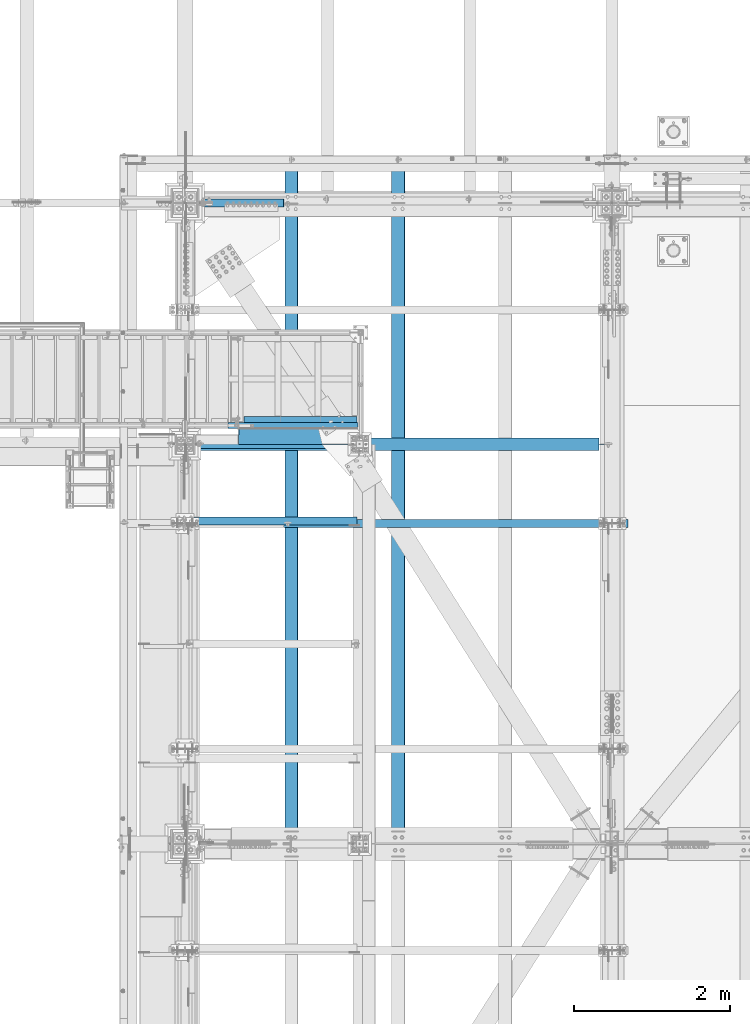
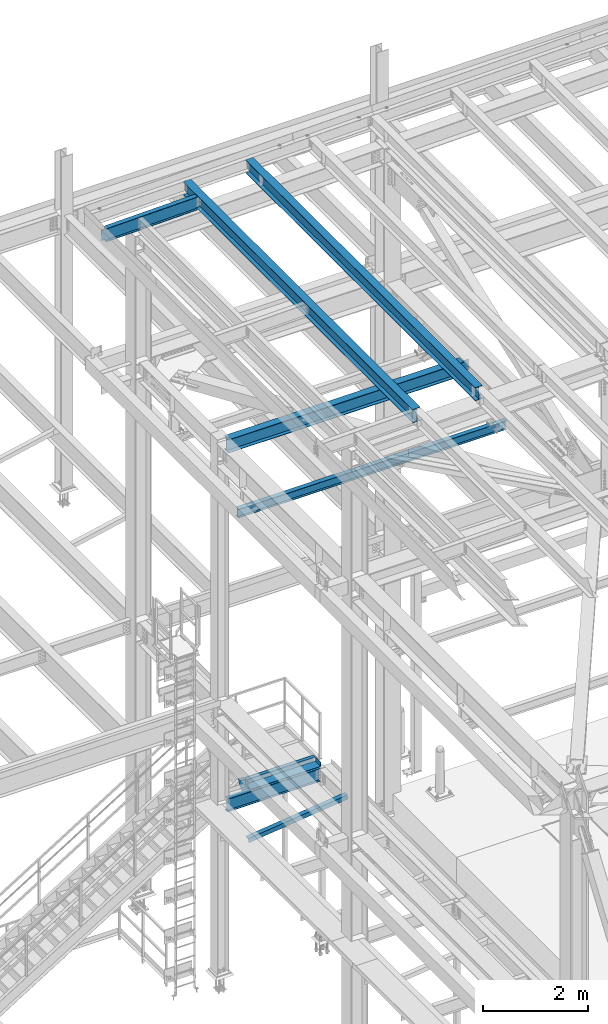
# One storey, part 1886 of 3843: 11 beams, 8 elements without a shape of their own.
"""IFC2X3 building model written with IfcOpenShell, lengths in millimetres."""

import ifcopenshell
import ifcopenshell.guid

model = None  # the IFC model being written
_history = None  # IfcOwnerHistory: only IFC2X3 demands one
_inside = {}  # id of a spatial element -> (the spatial element, [elements in it])
_under = {}  # id of a project, library or spatial element -> (it, [spatial elements below it])
_declared = {}  # id of a project -> (the project, [libraries it declares])
_typed = {}  # id of a type object -> (the type object, [elements of that type])
_made_of = {}  # id of a material, layer set ... -> (it, [elements and type objects made of it])


def new_model(schema):
    """Start an empty IFC model of exactly this schema.

    Asked for "IFC4X3", IfcOpenShell would pick the latest addendum, in which some entities
    have other attributes; the version numbers below select the first issue.
    IFC2X3 requires an IfcOwnerHistory on every rooted entity: one is made here for all.
    """
    global model, _history
    if schema == "IFC4X3":
        model = ifcopenshell.file(schema_version=(4, 3, 0, 0))
    else:
        model = ifcopenshell.file(schema=schema)
    _inside.clear()
    _under.clear()
    _declared.clear()
    _typed.clear()
    _made_of.clear()
    _history = None
    if model.schema == "IFC2X3":
        org = make("IfcOrganization", Name="unknown")
        user = make(
            "IfcPersonAndOrganization",
            ThePerson=make("IfcPerson", FamilyName="unknown"),
            TheOrganization=org,
        )
        app = make(
            "IfcApplication",
            ApplicationDeveloper=org,
            Version="unknown",
            ApplicationFullName="unknown",
            ApplicationIdentifier="unknown",
        )
        _history = make(
            "IfcOwnerHistory",
            OwningUser=user,
            OwningApplication=app,
            ChangeAction="ADDED",
            CreationDate=0,
        )
    return model


def make(cls, **values):
    """One entity of the class cls with the attributes given. An attribute that is None is left unset."""
    return model.create_entity(
        cls, **{name: value for name, value in values.items() if value is not None}
    )


def rooted(cls, **values):
    """An entity with a GlobalId (a new one), such as an element, a storey or a relation."""
    return make(cls, GlobalId=ifcopenshell.guid.new(), OwnerHistory=_history, **values)


def si_unit(unit_type, name, prefix=None):
    """IfcSIUnit, for example si_unit("LENGTHUNIT", "METRE", prefix="MILLI")."""
    return make("IfcSIUnit", UnitType=unit_type, Prefix=prefix, Name=name)


def assignment(units):
    """IfcUnitAssignment: the units of a project."""
    return None if units is None else make("IfcUnitAssignment", Units=units)


def point(xyz):
    """IfcCartesianPoint."""
    return None if xyz is None else make("IfcCartesianPoint", Coordinates=xyz)


def direction(xyz):
    """IfcDirection."""
    return None if xyz is None else make("IfcDirection", DirectionRatios=xyz)


def frame(location, z_axis=None, x_axis=None):
    """IfcAxis2Placement3D, a coordinate frame: its origin and axes. An axis left out is left unset."""
    return make(
        "IfcAxis2Placement3D",
        Location=point(location),
        Axis=direction(z_axis),
        RefDirection=direction(x_axis),
    )


def origin_with_axes():
    """The frame at (0, 0, 0) with the z axis (0, 0, 1) and the x axis (1, 0, 0) written out."""
    return frame((0.0, 0.0, 0.0), z_axis=(0.0, 0.0, 1.0), x_axis=(1.0, 0.0, 0.0))


def place(relative_to, where):
    """IfcLocalPlacement: puts the frame where relative to a parent placement (None: the world)."""
    return make(
        "IfcLocalPlacement", PlacementRelTo=relative_to, RelativePlacement=where
    )


def context(
    kind, dimensions, precision=None, world=None, true_north=None, identifier=None
):
    """IfcGeometricRepresentationContext, for example the 3D "Model" context."""
    return make(
        "IfcGeometricRepresentationContext",
        ContextIdentifier=identifier,
        ContextType=kind,
        CoordinateSpaceDimension=dimensions,
        Precision=precision,
        WorldCoordinateSystem=world,
        TrueNorth=true_north,
    )


def subcontext(parent, identifier, kind, view, scale=None):
    """IfcGeometricRepresentationSubContext, for example "Body" below "Model"."""
    return make(
        "IfcGeometricRepresentationSubContext",
        ContextIdentifier=identifier,
        ContextType=kind,
        ParentContext=parent,
        TargetScale=scale,
        TargetView=view,
    )


def project(units=None, contexts=None):
    """IfcProject with its units and contexts."""
    return rooted(
        "IfcProject",
        Name="project",
        RepresentationContexts=contexts,
        UnitsInContext=assignment(units),
    )


def spatial(cls, under=None, at=None, **own):
    """A site, building, storey or space (cls), placed at a placement, below another one or the project."""
    s = rooted(cls, ObjectPlacement=at, **own)
    if under is not None:
        _under.setdefault(under.id(), (under, []))[1].append(s)
    return s


def faces_of(points, faces, orient=None, outer=None):
    """IfcFace entities. A face is a list of loops; a loop is a list of indices into points, from 0.

    orient and outer hold one flag for each loop. By default every Orientation is true, the
    first loop of a face is its IfcFaceOuterBound and the others are IfcFaceBound.
    """
    made = []
    for i, loops in enumerate(faces):
        bounds = []
        for j, loop in enumerate(loops):
            is_outer = j == 0 if outer is None else outer[i][j]
            bounds.append(
                make(
                    "IfcFaceOuterBound" if is_outer else "IfcFaceBound",
                    Bound=make("IfcPolyLoop", Polygon=[points[k] for k in loop]),
                    Orientation=True if orient is None else orient[i][j],
                )
            )
        made.append(make("IfcFace", Bounds=bounds))
    return made


def faceted_brep(points, faces, orient=None, outer=None, voids=None):
    """IfcFacetedBrep: a solid bounded by flat faces; with voids (closed shells), ...WithVoids."""
    shared = [point(p) for p in points]
    hull = make("IfcClosedShell", CfsFaces=faces_of(shared, faces, orient, outer))
    if voids is None:
        return make("IfcFacetedBrep", Outer=hull)
    return make(
        "IfcFacetedBrepWithVoids",
        Outer=hull,
        Voids=[
            make(cls, CfsFaces=faces_of(shared, fs, o, b)) for cls, fs, o, b in voids
        ],
    )


def shape(context_of_items, identifier, shape_type, items):
    """IfcShapeRepresentation: the items that make up one representation, for example the "Body"."""
    return make(
        "IfcShapeRepresentation",
        ContextOfItems=context_of_items,
        RepresentationIdentifier=identifier,
        RepresentationType=shape_type,
        Items=items,
    )


def material(Name=None, Category=None):
    """IfcMaterial."""
    return make("IfcMaterial", Name=Name, Category=Category)


def made_of(thing, what):
    """Note that an element or type object is made of a material, layer set ...; save() writes the relation."""
    if what is not None:
        _made_of.setdefault(what.id(), (what, []))[1].append(thing)
    return thing


def type_object(cls, material=None, **own):
    """A type object (cls), such as IfcWallType, which elements share."""
    return made_of(rooted(cls, **own), material)


def element(
    cls,
    number,
    at=None,
    inside=None,
    cuts=None,
    type_object=None,
    material=None,
    context=None,
    identifier="Body",
    shape_type=None,
    held_by="IfcProductDefinitionShape",
    body=None,
    shapes=None,
    **own,
):
    """One element of the class cls, such as IfcWall. Its Tag is "e" and its number.

    at: its placement. inside: the storey or other place that contains it. cuts: it is an
    opening in that element (IfcRelVoidsElement). A single representation is given by context,
    identifier, shape_type and body (its items); several are given by shapes. held_by: the class
    of the entity that holds the representations. save() writes the other relations.
    """
    e = rooted(cls, Tag="e%d" % number, ObjectPlacement=at, **own)
    if body is not None:
        shapes = [shape(context, identifier, shape_type, body)]
    if shapes is not None:
        e.Representation = make(held_by, Representations=shapes)
    if inside is not None:
        _inside.setdefault(inside.id(), (inside, []))[1].append(e)
    if cuts is not None:
        rooted(
            "IfcRelVoidsElement", RelatingBuildingElement=cuts, RelatedOpeningElement=e
        )
    if type_object is not None:
        _typed.setdefault(type_object.id(), (type_object, []))[1].append(e)
    return made_of(e, material)


def aggregate(whole, parts):
    """IfcRelAggregates: a whole, such as a stair, and the parts it consists of."""
    return rooted("IfcRelAggregates", RelatingObject=whole, RelatedObjects=parts)


def save(model, path):
    """Write the relations noted so far, then the file.

    IfcRelAggregates (storeys below a building ...), IfcRelContainedInSpatialStructure (elements
    in a storey), IfcRelDefinesByType, IfcRelAssociatesMaterial and IfcRelDeclares: one each for
    every whole, place, type object, material and project.
    """
    for whole, parts in _under.values():
        aggregate(whole, parts)
    for where, things in _inside.values():
        rooted(
            "IfcRelContainedInSpatialStructure",
            RelatedElements=things,
            RelatingStructure=where,
        )
    for kind, things in _typed.values():
        rooted("IfcRelDefinesByType", RelatedObjects=things, RelatingType=kind)
    for what, things in _made_of.values():
        rooted("IfcRelAssociatesMaterial", RelatedObjects=things, RelatingMaterial=what)
    for by, libraries in _declared.values():
        rooted("IfcRelDeclares", RelatingContext=by, RelatedDefinitions=libraries)
    model.write(path)


model = new_model("IFC2X3")

# Units and contexts
model_context = context("Model", 3, precision=1e-05, world=origin_with_axes())
body_context = subcontext(model_context, "Body", "Model", "MODEL_VIEW")
ifc_project = project(units=[si_unit("LENGTHUNIT", "METRE", prefix="MILLI"), si_unit("AREAUNIT", "SQUARE_METRE"), si_unit("VOLUMEUNIT", "CUBIC_METRE"), si_unit("MASSUNIT", "GRAM", prefix="KILO"), si_unit("TIMEUNIT", "SECOND"), si_unit("PLANEANGLEUNIT", "RADIAN"), si_unit("SOLIDANGLEUNIT", "STERADIAN"), si_unit("THERMODYNAMICTEMPERATUREUNIT", "DEGREE_CELSIUS"), si_unit("LUMINOUSINTENSITYUNIT", "LUMEN")], contexts=[model_context])

# Site, building, storey
site_placement = place(None, origin_with_axes())
site = spatial("IfcSite", under=ifc_project, at=site_placement, CompositionType="ELEMENT")
building_placement = place(site_placement, origin_with_axes())
building = spatial("IfcBuilding", under=site, at=building_placement, Name="Undefined", CompositionType="ELEMENT")
storey_placement = place(building_placement, origin_with_axes())
storey = spatial("IfcBuildingStorey", under=building, at=storey_placement, Name="Undefined", CompositionType="ELEMENT", Elevation=0.0)

# Assembly, beams
assembly_1_placement = place(storey_placement, origin_with_axes())
assembly_1 = element("IfcElementAssembly", 1, at=assembly_1_placement, inside=storey, Name="STAIR", AssemblyPlace="NOTDEFINED", PredefinedType="RIGID_FRAME")
ifc_material_1 = material(Name="STEEL/A36")
beam_type_1 = type_object("IfcBeamType", PredefinedType="NOTDEFINED")
beam_1_placement = place(assembly_1_placement, frame((37261.7999999913, 89357.2000001144, 34134.425), z_axis=(0.0, 1.0, 0.0), x_axis=(1.0, 0.0, 0.0)))
beam_1 = element("IfcBeam", 2, at=beam_1_placement, type_object=beam_type_1, material=ifc_material_1, Name="PLATE", context=body_context, shape_type="Brep", body=[
    faceted_brep([(0.0, 3.17500000000291, -38.0999999999985), (0.0, 3.17500000000291, 38.0999999999985), (1533.52500000346, 3.17500000000291, 38.1000000000058), (1533.52500000346, 3.17500000000291, -38.1000000000058), (0.0, -3.17500000000291, 38.0999999999985), (1533.52500000346, -3.17500000000291, 38.1000000000058), (0.0, -3.17500000000291, -38.0999999999985), (1533.52500000346, -3.17500000000291, -38.1000000000058)], [[[0, 1, 2, 3]], [[1, 4, 5, 2]], [[4, 6, 7, 5]], [[6, 0, 3, 7]], [[5, 7, 3, 2]], [[6, 4, 1, 0]]]),
])
beam_type_2 = type_object("IfcBeamType", Name="C12X20.7", PredefinedType="NOTDEFINED")
beam_2_placement = place(assembly_1_placement, frame((37127.5314299188, 89357.2000000485, 34010.6000000117), z_axis=(0.0, 0.0, 1.0), x_axis=(1.0, 0.0, 0.0)))
beam_2 = element("IfcBeam", 3, at=beam_2_placement, type_object=beam_type_2, material=ifc_material_1, Name="STAIR", ObjectType="C12X20.7", context=body_context, shape_type="Brep", body=[
    faceted_brep([(134.268570070926, -38.1000000000058, 152.400000000001), (134.268570070926, -38.1000000000058, 146.047460000002), (134.268570070926, 30.1625000000058, 134.674927499997), (134.268570070926, 30.1625000000058, 120.650000074354), (134.268570070926, 38.1000000000058, 120.650000082271), (134.268570070926, 38.1000000000058, 152.400000000001), (1667.7935700748, 30.1625000000058, 120.650000074376), (1667.7935700725, 38.1000000000058, 120.650000082293), (87.2228414294514, -38.1000000000058, -152.400000000001), (85.4049720575931, -38.1000000000058, -146.047460000002), (82.1505606706269, 30.1625000000058, -134.674927499997), (5.07228147550632, 30.1625000000058, 134.674927499997), (1.8178700885328, -38.1000000000058, 146.047460000002), (0.0, -38.0999999999985, 152.400000000001), (0.0, 38.0999999999985, 152.400000000001), (87.2228414294514, 38.1000000000058, -152.400000000001), (1667.7935700725, 38.1000000000058, -152.400000000001), (1667.7935700725, -38.1000000000058, -152.400000000001), (1667.7935700725, -38.1000000000058, -146.047460000002), (1667.7935700725, 30.1625000000058, -134.674927499997)], [[[0, 1, 2, 3, 4, 5]], [[6, 7, 4, 3]], [[8, 9, 10, 11, 12, 13, 14, 15]], [[8, 15, 16, 17]], [[9, 8, 17, 18]], [[10, 9, 18, 19]], [[2, 11, 10, 19, 6, 3]], [[12, 11, 2, 1]], [[13, 12, 1, 0]], [[14, 13, 0, 5]], [[16, 15, 14, 5, 4, 7]], [[19, 18, 17, 16, 7, 6]]]),
])

# Assembly, beam
assembly_2_placement = place(storey_placement, origin_with_axes())
assembly_2 = element("IfcElementAssembly", 4, at=assembly_2_placement, inside=storey, Name="ANGLE", AssemblyPlace="NOTDEFINED", PredefinedType="RIGID_FRAME")
ifc_material_2 = material(Name="STEEL/A572-50")
beam_type_3 = type_object("IfcBeamType", Name="L4X4X3/8", PredefinedType="NOTDEFINED")
beam_3_placement = place(assembly_2_placement, frame((38788.5093206542, 88128.475, 33960.1419503901), z_axis=(0.0, 1.0, 0.0), x_axis=(-0.993268693078032, 0.0, -0.115833084009098)))
beam_3 = element("IfcBeam", 5, at=beam_3_placement, type_object=beam_type_3, material=ifc_material_2, Name="ANGLE", ObjectType="L4X4X3/8", context=body_context, shape_type="Brep", body=[
    faceted_brep([(0.0, 50.8000000000029, -50.8000000000029), (0.0, 50.8000000000029, 50.8000000000029), (2192.8104802954, 50.7999999940694, 50.8000000000029), (2192.8104802954, 50.7999999940694, -50.8000000000029), (0.0, 41.2750000000015, 50.8000000000029), (2192.81048029537, 41.2749999940788, 50.8000000000029), (0.0, 41.2749999999942, -41.2750000000015), (2192.81048029537, 41.2749999940788, -41.2750000000015), (0.0, -50.8000000000029, -41.2750000000015), (2192.81048029512, -50.8000000058528, -41.2750000000015), (0.0, -50.8000000000029, -50.8000000000029), (2192.81048029512, -50.8000000058528, -50.8000000000029)], [[[0, 1, 2, 3]], [[1, 4, 5, 2]], [[4, 6, 7, 5]], [[6, 8, 9, 7]], [[8, 10, 11, 9]], [[10, 0, 3, 11]], [[5, 7, 9, 11, 3, 2]], [[10, 8, 6, 4, 1, 0]]]),
])
aggregate(assembly_2, [beam_3])

assembly_3_placement = place(storey_placement, origin_with_axes())
assembly_3 = element("IfcElementAssembly", 6, at=assembly_3_placement, inside=storey, Name="BEAM", AssemblyPlace="NOTDEFINED", PredefinedType="RIGID_FRAME")
ifc_material_3 = material(Name="STEEL/A992")
beam_type_4 = type_object("IfcBeamType", Name="W12X26", PredefinedType="NOTDEFINED")
beam_4_placement = place(assembly_3_placement, frame((36576.0, 89115.9, 42246.55), z_axis=(0.0, 0.0, 1.0), x_axis=(1.0, 0.0, 0.0)))
beam_4 = element("IfcBeam", 7, at=beam_4_placement, type_object=beam_type_4, material=ifc_material_3, Name="BEAM", ObjectType="W12X26", context=body_context, shape_type="Brep", body=[
    faceted_brep([(5314.95, -3.17500000000291, -146.050000000003), (5314.95, -82.5500000000029, -146.050000000003), (5314.95, -82.5500000000029, -155.574999999997), (5314.95, 82.5500000000029, -155.574999999997), (5314.95, 82.5500000000029, -146.050000000003), (5314.95, 3.17500000000291, -146.050000000003), (5314.95, 3.17500000000291, -136.524999795321), (5314.95, -3.17500000000291, -136.524999795321), (5315.9167299226, 3.17500000000291, -131.664920277275), (5315.9167299226, -3.17500000000291, -131.664920277275), (5318.66974382307, 3.17500000000291, -127.544743809121), (5318.66974382307, -3.17500000000291, -127.544743809121), (5322.78992029122, 3.17500000000291, -124.791729908648), (5322.78992029122, -3.17500000000291, -124.791729908648), (5327.64999980927, 3.17500000000291, -123.824999986056), (5327.64999980927, -3.17500000000291, -123.824999986056), (5467.35000000001, -3.17500000000291, -123.824999986056), (5467.35000000001, 3.17500000000291, -123.824999986056), (142.875, 3.17500000000291, 146.050000000003), (142.875, 82.5500000000029, 146.050000000003), (5314.95, 82.5500000000029, 146.050000000003), (5314.95, 3.17500000000291, 146.050000000003), (142.875, -82.5500000000029, -155.574999999997), (142.875, -82.5500000000029, -146.050000000003), (142.875, -3.17500000000291, -146.050000000003), (142.875, -3.17500000000291, 146.050000000003), (142.875, -82.5500000000029, 146.050000000003), (142.875, -82.5500000000029, 155.574999999997), (142.875, 82.5500000000029, 155.574999999997), (142.875, 3.17500000000291, 117.474999999999), (142.875, 3.17500000000291, -113.125), (142.875, 3.17500000000291, -146.050000000003), (142.875, 82.5500000000029, -146.050000000003), (142.875, 82.5500000000029, -155.574999999997), (5314.95, -3.17500000000291, 146.050000000003), (5314.95, -82.5500000000029, 146.050000000003), (5314.95, -82.5500000000029, 155.574999999997), (5314.95, 82.5500000000029, 155.574999999997), (5314.95, -3.17500000000291, 136.52499982321), (5314.95, 3.17500000000291, 136.52499982321), (5315.9167299226, -3.17500000000291, 131.664920305164), (5315.9167299226, 3.17500000000291, 131.664920305164), (5318.66974382307, -3.17500000000291, 127.54474383701), (5318.66974382307, 3.17500000000291, 127.54474383701), (5322.78992029122, -3.17500000000291, 124.791729936536), (5322.78992029122, 3.17500000000291, 124.791729936536), (5327.64999980927, -3.17500000000291, 123.825000013945), (5327.64999980927, 3.17500000000291, 123.825000013945), (5467.35000000001, -3.17500000000291, 123.825000013945), (5467.35000000001, 3.17500000000291, 123.825000013945), (5467.35000000001, 3.17500000000291, -113.124999975276), (5467.35000000001, 3.17500000000291, 117.475000024722)], [[[0, 1, 2, 3, 4, 5, 6, 7]], [[7, 6, 8, 9]], [[9, 8, 10, 11]], [[11, 10, 12, 13]], [[13, 12, 14, 15]], [[16, 15, 14, 17]], [[18, 19, 20, 21]], [[22, 23, 24, 25, 26, 27, 28, 19, 18, 29, 30, 31, 32, 33]], [[26, 25, 34, 35]], [[27, 26, 35, 36]], [[28, 27, 36, 37]], [[19, 28, 37, 20]], [[36, 35, 34, 38, 39, 21, 20, 37]], [[40, 41, 39, 38]], [[42, 43, 41, 40]], [[44, 45, 43, 42]], [[46, 47, 45, 44]], [[48, 49, 47, 46]], [[50, 51, 49, 48, 16, 17]], [[12, 10, 8, 6, 5, 31, 30, 29, 18, 21, 39, 41, 43, 45, 47, 49, 51, 50, 17, 14]], [[32, 31, 5, 4]], [[33, 32, 4, 3]], [[22, 33, 3, 2]], [[23, 22, 2, 1]], [[24, 23, 1, 0]], [[48, 46, 44, 42, 40, 38, 34, 25, 24, 0, 7, 9, 11, 13, 15, 16]]]),
])
aggregate(assembly_3, [beam_4])

assembly_4_placement = place(storey_placement, origin_with_axes())
assembly_4 = element("IfcElementAssembly", 8, at=assembly_4_placement, inside=storey, Name="BEAM", AssemblyPlace="NOTDEFINED", PredefinedType="RIGID_FRAME")
beam_5_placement = place(assembly_4_placement, frame((39315.9092623549, 83985.1232899491, 45633.2761568835), z_axis=(-0.0211520982443035, 0.000149702000009711, 0.999776258134376), x_axis=(0.0, 0.999999988789565, -0.000149735999968411)))
beam_5 = element("IfcBeam", 9, at=beam_5_placement, type_object=beam_type_4, material=ifc_material_3, Name="BEAM", ObjectType="W12X26", context=body_context, shape_type="Brep", body=[
    faceted_brep([(8748.71286122, -3.17499999989377, -146.049999991708), (8748.71286122002, -82.5499999997555, -146.049999991512), (8748.71286122, -82.5499999997337, -155.574999991521), (8748.71286122, 82.5499999999884, -155.574999991921), (8748.71286122002, 82.5499999999738, -146.049999991912), (8748.71286122, 3.17500000010477, -146.049999991723), (8748.7128612212, 3.1750000000975, -142.874999700573), (8748.71286122112, -3.17499999989377, -142.874999700529), (8749.67959114375, 3.17500000009022, -138.014920182519), (8749.67959114365, -3.17499999990105, -138.014920182482), (8752.4326050442, 3.17500000008295, -133.89474371438), (8752.43260504413, -3.17499999990832, -133.894743714329), (8756.55278151239, 3.17500000007567, -131.141729813913), (8756.55278151232, -3.1749999999156, -131.141729813869), (8761.41286103048, 3.17500000007567, -130.174999891344), (8761.4128610304, -3.1749999999156, -130.174999891293), (8818.5587864485, -3.1749999999156, -130.174999891518), (8818.55880656045, 3.17500000007567, -130.174999891511), (12.6548561980599, 3.17499999971915, 146.050000000178), (12.6551075974858, 82.5499999995809, 146.049999999988), (8748.71286121653, 82.549999999399, 146.050000008428), (8748.71286121651, 3.17499999954453, 146.050000008618), (12.6997740084771, -82.5500000001266, -155.575000000601), (12.6983127888088, -82.5499999995736, -146.049999999959), (12.6985153056303, -3.1750000001266, -146.049999999974), (12.6548360861052, -3.17500000027212, 146.050000000192), (12.6545846867084, -82.5500000001339, 146.050000000389), (12.6531587703212, -82.5500000001557, 155.575000000397), (12.6536816811131, 82.5499999995664, 155.57499999999), (12.6985359631362, 3.17499999986467, -146.049999999996), (12.6987941820043, 82.549999999741, -146.050000000265), (12.7002263236427, 82.5499999995591, -155.575000000172), (8748.71286121651, -3.17500000044674, 146.050000008632), (8748.71286121651, -82.5500000003158, 146.050000008829), (8748.71286121653, -82.5500000003376, 155.575000008837), (8748.71286121653, 82.5499999993917, 155.575000008437), (8748.71286121788, -3.17500000044674, 142.874999919026), (8748.71286121797, 3.17499999954453, 142.874999918989), (8749.67959114054, -3.17500000043947, 138.01492040095), (8749.67959114061, 3.1749999995518, 138.014920400907), (8752.4326050411, -3.17500000041764, 133.894743932753), (8752.43260504119, 3.17499999956635, 133.894743932709), (8756.55278150937, -3.17500000041764, 131.141730032243), (8756.55278150944, 3.17499999956635, 131.141730032199), (8761.41286102751, -3.17500000041764, 130.175000109637), (8761.41286102759, 3.17499999957363, 130.175000109593), (8818.51981140097, -3.17500000041764, 130.175000110881), (8818.51983151292, 3.17499999956635, 130.175000110889), (8818.55625342086, 3.17500000003929, -113.120244814017), (8818.52173202329, 3.17499999958818, 117.479752603125)], [[[0, 1, 2, 3, 4, 5, 6, 7]], [[7, 6, 8, 9]], [[9, 8, 10, 11]], [[11, 10, 12, 13]], [[13, 12, 14, 15]], [[16, 15, 14, 17]], [[18, 19, 20, 21]], [[22, 23, 24, 25, 26, 27, 28, 19, 18, 29, 30, 31]], [[26, 25, 32, 33]], [[27, 26, 33, 34]], [[28, 27, 34, 35]], [[19, 28, 35, 20]], [[34, 33, 32, 36, 37, 21, 20, 35]], [[38, 39, 37, 36]], [[40, 41, 39, 38]], [[42, 43, 41, 40]], [[44, 45, 43, 42]], [[46, 47, 45, 44]], [[48, 49, 47, 46, 16, 17]], [[12, 10, 8, 6, 5, 29, 18, 21, 37, 39, 41, 43, 45, 47, 49, 48, 17, 14]], [[30, 29, 5, 4]], [[31, 30, 4, 3]], [[22, 31, 3, 2]], [[23, 22, 2, 1]], [[24, 23, 1, 0]], [[46, 44, 42, 40, 38, 36, 32, 25, 24, 0, 7, 9, 11, 13, 15, 16]]]),
])
aggregate(assembly_4, [beam_5])

assembly_5_placement = place(storey_placement, origin_with_axes())
assembly_5 = element("IfcElementAssembly", 10, at=assembly_5_placement, inside=storey, Name="BEAM", AssemblyPlace="NOTDEFINED", PredefinedType="RIGID_FRAME")
beam_6_placement = place(assembly_5_placement, frame((37944.3092623846, 83985.1116450134, 45603.5956776366), z_axis=(-0.0211520980636923, 7.39979999707428e-05, 0.999776266607585), x_axis=(2.20000000365173e-08, 0.99999999726089, -7.40150000196403e-05)))
beam_6 = element("IfcBeam", 11, at=beam_6_placement, type_object=beam_type_4, material=ifc_material_3, Name="BEAM", ObjectType="W12X26", context=body_context, shape_type="Brep", body=[
    faceted_brep([(8748.712654394, -3.17499999990105, -146.050000027157), (8748.712654394, -82.549999999741, -146.050000027375), (8748.71265439395, -82.5499999997846, -155.575000027362), (8748.71265439395, 82.5499999998865, -155.575000026911), (8748.71265439398, 82.5499999999156, -146.050000026917), (8748.71265439398, 3.17500000007567, -146.050000027135), (8748.71265439461, 3.17500000008295, -142.875000296546), (8748.71265439456, -3.17499999990105, -142.875000296604), (8749.67938431721, 3.1750000000975, -138.014920778529), (8749.67938431716, -3.17499999987922, -138.01492077858), (8752.43239821767, 3.17500000011933, -133.894744310397), (8752.43239821763, -3.17499999987194, -133.894744310455), (8756.55257468575, 3.17500000013388, -131.141730409945), (8756.5525746857, -3.17499999985739, -131.141730410003), (8761.4126542037, 3.17500000013388, -130.175000487376), (8761.41265420365, -3.17499999985739, -130.175000487427), (8818.56061830452, -3.17499999985012, -130.175000488431), (8818.56062836049, 3.17500000013388, -130.175000488445), (12.6774280250684, 3.1750000004904, 146.049999999806), (12.677553724774, 82.5500000003303, 146.050000000032), (8748.71265439989, 82.5500000009051, 146.049999972733), (8748.71265439989, 3.1750000010652, 146.049999972514), (12.6998726767124, -82.5500000001921, -155.575000000106), (12.6991678371196, -82.5500000001703, -146.050000000097), (12.6992903581922, -3.17500000032305, -146.050000000112), (12.6774179690838, -3.17499999948632, 146.049999999792), (12.6772922693635, -82.5499999993262, 146.049999999574), (12.6765793112281, -82.5499999992971, 155.574999999561), (12.6768407666386, 82.5500000003667, 155.575000000019), (12.6993001598748, 3.17499999966822, -146.050000000112), (12.6994226809475, 82.5499999995009, -146.050000000127), (12.700127520533, 82.5499999994863, -155.575000000135), (8748.71265439989, -3.17499999891152, 146.049999972493), (8748.7126543999, -82.5499999987442, 146.049999972274), (8748.71265439993, -82.5499999987151, 155.574999972268), (8748.71265439993, 82.5500000009415, 155.57499997272), (8748.7126544004, -3.17499999892607, 142.874999320913), (8748.71265440043, 3.17500000105792, 142.874999320964), (8749.67938432295, -3.1749999989479, 138.014919802874), (8749.67938432298, 3.1750000010361, 138.014919802932), (8752.43239822335, -3.17499999896245, 133.894743334728), (8752.43239822339, 3.17500000102882, 133.894743334778), (8756.55257469141, -3.17499999896972, 131.141729434246), (8756.55257469145, 3.17500000101427, 131.141729434305), (8761.41265420937, -3.17499999896245, 130.174999511655), (8761.41265420943, 3.17500000101427, 130.174999511706), (8818.54113078186, -3.17499999896972, 130.174999510367), (8818.54114083783, 3.17500000101427, 130.174999510346), (8818.55935196872, 3.17500000019936, -113.122622912517), (8818.54209127078, 3.17500000097789, 117.477376435221)], [[[0, 1, 2, 3, 4, 5, 6, 7]], [[7, 6, 8, 9]], [[9, 8, 10, 11]], [[11, 10, 12, 13]], [[13, 12, 14, 15]], [[16, 15, 14, 17]], [[18, 19, 20, 21]], [[22, 23, 24, 25, 26, 27, 28, 19, 18, 29, 30, 31]], [[26, 25, 32, 33]], [[27, 26, 33, 34]], [[28, 27, 34, 35]], [[19, 28, 35, 20]], [[34, 33, 32, 36, 37, 21, 20, 35]], [[38, 39, 37, 36]], [[40, 41, 39, 38]], [[42, 43, 41, 40]], [[44, 45, 43, 42]], [[46, 47, 45, 44]], [[48, 49, 47, 46, 16, 17]], [[12, 10, 8, 6, 5, 29, 18, 21, 37, 39, 41, 43, 45, 47, 49, 48, 17, 14]], [[30, 29, 5, 4]], [[31, 30, 4, 3]], [[22, 31, 3, 2]], [[23, 22, 2, 1]], [[24, 23, 1, 0]], [[46, 44, 42, 40, 38, 36, 32, 25, 24, 0, 7, 9, 11, 13, 15, 16]]]),
])
aggregate(assembly_5, [beam_6])

# Beam
beam_type_5 = type_object("IfcBeamType", Name="L3X3X1/4", PredefinedType="NOTDEFINED")
beam_7_placement = place(assembly_1_placement, frame((38782.6249999936, 89433.4000000849, 34048.7000000118), z_axis=(0.0, 1.0, 0.0), x_axis=(-1.0, 0.0, 0.0)))
beam_7 = element("IfcBeam", 12, at=beam_7_placement, type_object=beam_type_5, material=ifc_material_1, Name="ANGLE", ObjectType="L3X3X1/4", context=body_context, shape_type="Brep", body=[
    faceted_brep([(0.0, 38.0999999999985, -38.0999999999985), (0.0, 38.0999999999985, 38.0999999999985), (1450.97500000388, 38.0999999999985, 38.1000000000058), (1450.97500000388, 38.0999999999985, -38.1000000000058), (0.0, 31.75, 38.0999999999985), (1450.97500000388, 31.75, 38.1000000000058), (0.0, 31.75, -31.75), (1450.97500000388, 31.75, -31.75), (0.0, -38.0999999999985, -31.75), (1450.97500000388, -38.0999999999985, -31.75), (0.0, -38.0999999999985, -38.0999999999985), (1450.97500000388, -38.0999999999985, -38.1000000000058)], [[[0, 1, 2, 3]], [[1, 4, 5, 2]], [[4, 6, 7, 5]], [[6, 8, 9, 7]], [[8, 10, 11, 9]], [[10, 0, 3, 11]], [[5, 7, 9, 11, 3, 2]], [[10, 8, 6, 4, 1, 0]]]),
])

aggregate(assembly_1, [beam_1, beam_7, beam_2])

# Assembly, beam
assembly_6_placement = place(storey_placement, origin_with_axes())
assembly_6 = element("IfcElementAssembly", 13, at=assembly_6_placement, inside=storey, Name="BEAM", AssemblyPlace="NOTDEFINED", PredefinedType="RIGID_FRAME")
beam_type_6 = type_object("IfcBeamType", PredefinedType="NOTDEFINED")
beam_8_placement = place(assembly_6_placement, frame((37264.9886704879, 89217.4999995969, 34137.5995719223), z_axis=(0.0, 1.0, 0.0), x_axis=(-0.000134551999977022, 4.9999291933285e-09, -0.99999999094788)))
beam_8 = element("IfcBeam", 14, at=beam_8_placement, type_object=beam_type_6, material=ifc_material_1, Name="BENT_PLATE", context=body_context, shape_type="Brep", body=[
    faceted_brep([(95.0515630808804, 3.17500003185705, 19.0499999285676), (95.050708675677, -3.17499996814149, 19.049999928553), (7.34544300939888e-06, -3.17500000000291, 19.0499452738004), (7.34331842977554e-06, 3.17500000000291, 19.0499452733056), (95.0515624425461, 3.17500003184978, -101.600036644872), (95.0507080373427, -3.17499996814877, -101.600036644551), (95.2516169301671, -3.17499996808328, 101.599963278015), (95.2466752458422, -3.17499996809056, -101.60003672009), (95.24911732693, -3.67986297828611, 101.599875236672), (95.2490396408248, -3.67500028877839, -101.600124705132), (94.5443994635061, -1524.00149578538, 101.563490545901), (95.0445549942015, -1524.00164085521, 101.563493164445), (95.0444773290219, -1523.99662262001, -101.636506773633), (94.5444773230847, -1523.99663311679, -101.636509395903), (-0.205444538813026, -1523.98388432452, -101.636545396585), (-0.205522398384346, -1523.98874699311, 101.563454545219), (101.59752970664, 3.17500003405439, -101.600039168508), (101.599039583351, -3.67585469389451, -101.60012715323), (101.393622866373, -1530.34747696584, -101.636661180455), (94.5436229178958, -1530.3466330575, -101.636661354627), (-0.206298944001901, -1530.33388426522, -101.636697355309), (101.602471390957, 3.17500003405439, 101.599960829597), (101.599117269448, -3.68071738340223, 101.599872788574), (101.393700531538, -1530.35249520104, 101.563338757624), (94.5435450583172, -1530.35149572608, 101.563338587177), (-0.206376803573221, -1530.33874693382, 101.563302586495), (0.0, 3.17499999999927, 101.600000000006), (0.0, -3.17499999999927, 101.600000000006)], [[[0, 1, 2, 3]], [[4, 5, 1, 0]], [[6, 7, 8]], [[9, 8, 7]], [[10, 11, 12, 13, 14, 15]], [[8, 9, 12, 11]], [[13, 12, 9, 7, 5, 4, 16, 17, 18, 19, 20, 14]], [[16, 21, 17]], [[22, 17, 21]], [[17, 22, 23, 18]], [[19, 18, 23, 24, 25, 20]], [[15, 14, 20, 25]], [[24, 23, 22, 8, 11, 10, 15, 25]], [[21, 26, 27, 6, 8, 22]], [[27, 26, 3, 2]], [[7, 6, 27, 2, 1, 5]], [[26, 21, 16, 4, 0, 3]]]),
])

assembly_7_placement = place(storey_placement, origin_with_axes())
assembly_7 = element("IfcElementAssembly", 15, at=assembly_7_placement, inside=storey, Name="BEAM", AssemblyPlace="NOTDEFINED", PredefinedType="RIGID_FRAME")
beam_type_7 = type_object("IfcBeamType", Name="W12X19", PredefinedType="NOTDEFINED")
beam_9_placement = place(assembly_7_placement, frame((35741.0571586918, 92214.7, 45557.9079249894), z_axis=(-0.0211520980073474, 0.0, 0.999776269347241), x_axis=(0.999776270257024, 0.0, 0.0211520550054619)))
beam_9 = element("IfcBeam", 16, at=beam_9_placement, type_object=beam_type_7, material=ifc_material_3, Name="BEAM", ObjectType="W12X19", context=body_context, shape_type="Brep", body=[
    faceted_brep([(2105.28760845413, -3.17500000000291, -144.462499997644), (2105.28760845413, -50.8000000000029, -144.462499997644), (2105.28760845414, -50.8000000000029, -153.987499997631), (2105.28760845414, 50.8000000000029, -153.987499997631), (2105.28760845413, 50.8000000000029, -144.462499997644), (2105.28760845413, 3.17500000000291, -144.462499997644), (2105.28760845413, 3.17500000000291, -141.28749993231), (2105.28760845413, -3.17500000000291, -141.28749993231), (2106.2543383767, 3.17500000000291, -136.427420414293), (2106.2543383767, -3.17500000000291, -136.427420414293), (2109.00735227716, 3.17500000000291, -132.307243946154), (2109.00735227716, -3.17500000000291, -132.307243946154), (2113.1275287453, 3.17500000000291, -129.55423004568), (2113.1275287453, -3.17500000000291, -129.55423004568), (2117.98760826332, 3.17500000000291, -128.587500123096), (2117.98760826332, -3.17500000000291, -128.587500123096), (2187.83753302703, -3.17500000000291, -128.587500123031), (2187.8375229728, 3.17500000000291, -128.587500123023), (96.8374980314547, 3.17500000000291, 144.462500000489), (96.8374980314547, 50.8000000000029, 144.462500000489), (2105.28760845168, 50.8000000000029, 144.462500001886), (2105.28760845168, 3.17500000000291, 144.462500001886), (96.8374977455387, -3.17500000000291, -141.287499907492), (96.8374977455387, 3.17500000000291, -141.287499907492), (96.8374977423518, 3.17500000000291, -144.462499999776), (96.8374977423518, 50.8000000000029, -144.462499999776), (96.8374977328203, 50.8000000000029, -153.987499999792), (96.8374977328203, -50.8000000000029, -153.987499999792), (96.8374977423518, -50.8000000000029, -144.462499999776), (96.8374977423518, -3.17500000000291, -144.462499999776), (95.8707678278151, -3.17500000000291, -136.427420388471), (95.8707678278151, 3.17500000000291, -136.427420388471), (93.1177539315104, -3.17500000000291, -132.307243917545), (93.1177539315104, 3.17500000000291, -132.307243917545), (88.9975774661289, -3.17500000000291, -129.554230012938), (88.9975774661289, 3.17500000000291, -129.554230012938), (84.1374979491229, -3.17500000000291, -128.587500085479), (84.1374979491229, 3.17500000000291, -128.587500085479), (20.6374979119428, -3.17500000000291, -128.587500021946), (20.6374979119428, 3.17500000000291, -128.587500021946), (20.637498196942, -3.17499999998836, -114.712499731744), (20.637499580218, -3.17499999998836, 115.887500264478), (20.637499711811, -3.17500000000291, 128.587499979069), (20.637499711811, 3.17500000000291, 128.587499979069), (84.1374982064444, -3.17500000000291, 128.587499915513), (84.1374982064444, 3.17500000000291, 128.587499915513), (88.9975777254003, -3.17500000000291, 129.554229833244), (88.9975777254003, 3.17500000000291, 129.554229833244), (93.1177541962679, -3.17500000000291, 132.307243729607), (93.1177541962679, 3.17500000000291, 132.307243729607), (95.8707681008382, -3.17500000000291, 136.427420195025), (95.8707681008382, 3.17500000000291, 136.427420195025), (96.8374980282824, -3.17500000000291, 141.287499712118), (96.8374980282824, 3.17500000000291, 141.287499712118), (96.8374980410154, -50.8000000000029, 153.987499285155), (96.8374980410008, 50.8000000000029, 153.987500000498), (96.8374980314547, -3.17500000000291, 144.462500000489), (96.8374980314547, -50.8000000000029, 144.462500000489), (2105.28760845168, -3.17500000000291, 144.462500001886), (2105.28760845168, -50.8000000000029, 144.462500001886), (2105.28760845168, -50.8000000000029, 153.987499994), (2105.28760845168, 50.8000000000029, 153.987500001873), (2105.28760845169, -3.17500000000291, 141.287499684891), (2105.28760845169, 3.17500000000291, 141.287499684891), (2106.25433837427, -3.17500000000291, 136.42742016686), (2106.25433837427, 3.17500000000291, 136.42742016686), (2109.00735227474, -3.17500000000291, 132.307243698728), (2109.00735227474, 3.17500000000291, 132.307243698728), (2113.12752874288, -3.17500000000291, 129.554229798276), (2113.12752874288, 3.17500000000291, 129.554229798276), (2117.98760826091, -3.17500000000291, 128.587499875692), (2117.98760826091, 3.17500000000291, 128.587499875692), (2187.83753302702, -3.17500000000291, 128.587499875764), (2187.83752297279, 3.17500000000291, 128.587499875764), (2187.83753302703, -3.17500000000291, 115.88749997336), (2187.83753302703, -3.17500000000291, -114.712500017522)], [[[0, 1, 2, 3, 4, 5, 6, 7]], [[7, 6, 8, 9]], [[9, 8, 10, 11]], [[11, 10, 12, 13]], [[13, 12, 14, 15]], [[16, 15, 14, 17]], [[18, 19, 20, 21]], [[22, 23, 24, 25, 26, 27, 28, 29]], [[30, 31, 23, 22]], [[32, 33, 31, 30]], [[34, 35, 33, 32]], [[36, 37, 35, 34]], [[38, 39, 37, 36]], [[40, 41, 42, 43, 39, 38]], [[44, 45, 43, 42]], [[46, 47, 45, 44]], [[48, 49, 47, 46]], [[50, 51, 49, 48]], [[52, 53, 51, 50]], [[54, 55, 19, 18, 53, 52, 56, 57]], [[57, 56, 58, 59]], [[54, 57, 59, 60]], [[55, 54, 60, 61]], [[19, 55, 61, 20]], [[60, 59, 58, 62, 63, 21, 20, 61]], [[64, 65, 63, 62]], [[66, 67, 65, 64]], [[68, 69, 67, 66]], [[70, 71, 69, 68]], [[72, 73, 71, 70]], [[73, 72, 74, 75, 16, 17]], [[12, 10, 8, 6, 5, 24, 23, 31, 33, 35, 37, 39, 43, 45, 47, 49, 51, 53, 18, 21, 63, 65, 67, 69, 71, 73, 17, 14]], [[25, 24, 5, 4]], [[26, 25, 4, 3]], [[27, 26, 3, 2]], [[28, 27, 2, 1]], [[29, 28, 1, 0]], [[75, 74, 72, 70, 68, 66, 64, 62, 58, 56, 52, 50, 48, 46, 44, 42, 41, 40, 38, 36, 34, 32, 30, 22, 29, 0, 7, 9, 11, 13, 15, 16]]]),
])
aggregate(assembly_7, [beam_9])

assembly_8_placement = place(storey_placement, origin_with_axes())
assembly_8 = element("IfcElementAssembly", 17, at=assembly_8_placement, inside=storey, Name="BEAM", AssemblyPlace="NOTDEFINED", PredefinedType="RIGID_FRAME")
beam_type_8 = type_object("IfcBeamType", Name="W8X13", PredefinedType="NOTDEFINED")
beam_10_placement = place(assembly_8_placement, frame((36372.8, 88099.9, 41402.0), z_axis=(0.0, 0.0, 1.0), x_axis=(1.0, 0.0, 0.0)))
beam_10 = element("IfcBeam", 18, at=beam_10_placement, type_object=beam_type_8, material=ifc_material_3, Name="BEAM", ObjectType="W8X13", context=body_context, shape_type="Brep", body=[
    faceted_brep([(0.0, 50.7999999999993, -101.599999999999), (0.0, 50.7999999999993, -95.25), (5892.8, 50.7999999999993, -95.25), (5892.8, 50.7999999999993, -101.599999999999), (0.0, 3.17499999999927, -95.25), (5892.8, 3.17499999999927, -95.25), (-2.44140610448085e-05, 3.17500000000291, 95.2499999999927), (5892.8, 3.17499999999927, 95.25), (0.0, 50.7999999999993, 95.25), (5892.8, 50.7999999999993, 95.25), (0.0, 50.7999999999993, 101.599999999999), (5892.8, 50.7999999999993, 101.599999999999), (0.0, -50.7999999999993, 101.599999999999), (5892.8, -50.7999999999993, 101.599999999999), (0.0, -50.7999999999993, 95.25), (5892.8, -50.7999999999993, 95.25), (0.0, -3.17499999999927, 95.25), (5892.8, -3.17499999999927, 95.25), (0.0, -3.17499999999927, -95.25), (5892.8, -3.17499999999927, -95.25), (0.0, -50.7999999999993, -95.25), (5892.8, -50.7999999999993, -95.25), (0.0, -50.7999999999993, -101.599999999999), (5892.8, -50.7999999999993, -101.599999999999)], [[[0, 1, 2, 3]], [[1, 4, 5, 2]], [[4, 6, 7, 5]], [[6, 8, 9, 7]], [[8, 10, 11, 9]], [[10, 12, 13, 11]], [[12, 14, 15, 13]], [[14, 16, 17, 15]], [[16, 18, 19, 17]], [[18, 20, 21, 19]], [[20, 22, 23, 21]], [[22, 0, 3, 23]], [[5, 7, 9, 11, 13, 15, 17, 19, 21, 23, 3, 2]], [[22, 20, 18, 16, 14, 12, 10, 8, 6, 4, 1, 0]]]),
])
aggregate(assembly_8, [beam_10])

# Beam
beam_type_9 = type_object("IfcBeamType", Name="W12X14", PredefinedType="NOTDEFINED")
beam_11_placement = place(assembly_6_placement, frame((36576.0, 89115.9, 33885.1875), z_axis=(0.0, 0.0, 1.0), x_axis=(1.0, 0.0, 0.0)))
beam_11 = element("IfcBeam", 19, at=beam_11_placement, type_object=beam_type_9, material=ifc_material_3, Name="BEAM", ObjectType="W12X14", context=body_context, shape_type="Brep", body=[
    faceted_brep([(142.875, -50.8000000000029, -150.8125), (142.875, 50.8000000000029, -150.8125), (2181.225, 50.8000000000029, -150.8125), (2181.225, -50.8000000000029, -150.8125), (142.875, -50.8000000000029, -144.462500000001), (142.875, -2.38125000000582, -144.462500000001), (142.875, -2.38125000000582, 144.462500000001), (142.875, -50.8000000000029, 144.462500000001), (142.875, -50.8000000000029, 150.8125), (142.875, 50.8000000000029, 150.8125), (142.875, 50.8000000000029, 144.462500000001), (142.875, 2.38125000000582, 144.462500000001), (142.875, 2.38125000000582, -144.462500000001), (142.875, 50.8000000000029, -144.462500000001), (2181.225, -50.8000000000029, -144.462500000001), (2181.225, -2.38125000000582, -144.462500000001), (2181.225, -2.38125000000582, 144.462500000001), (2181.225, -50.8000000000029, 144.462500000001), (2181.225, -50.8000000000029, 150.8125), (2181.225, 50.8000000000029, 150.8125), (2181.225, 50.8000000000029, 144.462500000001), (2181.225, 2.38125000000582, 144.462500000001), (2181.225, 2.38125000000582, -144.462500000001), (2181.225, 50.8000000000029, -144.462500000001)], [[[0, 1, 2, 3]], [[0, 4, 5, 6, 7, 8, 9, 10, 11, 12, 13, 1]], [[5, 4, 14, 15]], [[6, 5, 15, 16]], [[7, 6, 16, 17]], [[8, 7, 17, 18]], [[9, 8, 18, 19]], [[10, 9, 19, 20]], [[11, 10, 20, 21]], [[12, 11, 21, 22]], [[13, 12, 22, 23]], [[1, 13, 23, 2]], [[22, 21, 20, 19, 18, 17, 16, 15, 14, 3, 2, 23]], [[4, 0, 3, 14]]]),
])

aggregate(assembly_6, [beam_8, beam_11])

save(model, "model.ifc")
